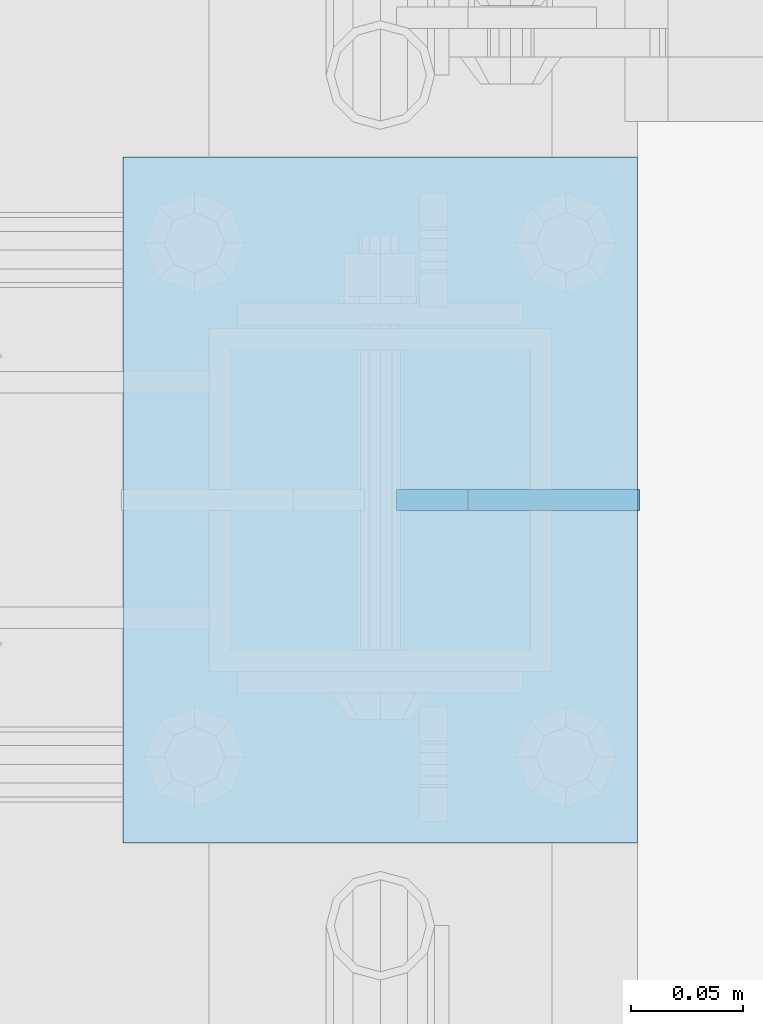
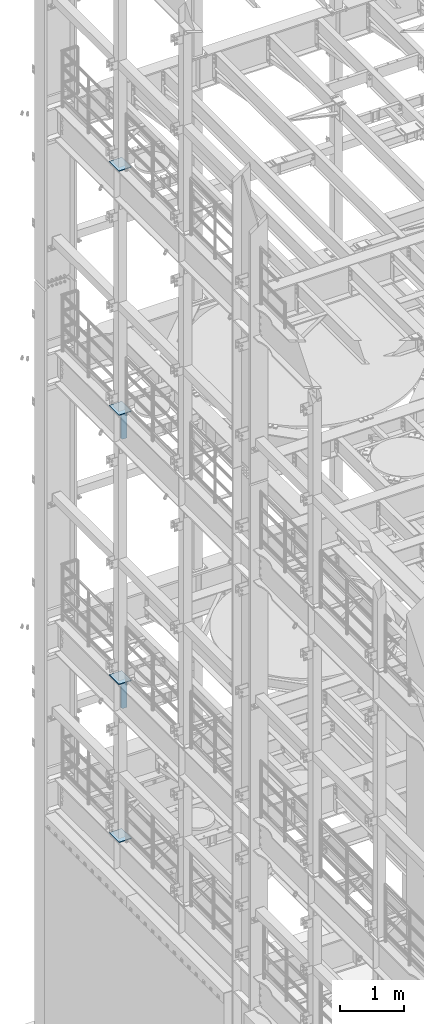
# One storey, part 1752 of 1876: 6 plates, 6 elements without a shape of their own.
"""IFC2X3 building model written with IfcOpenShell, lengths in millimetres."""

from ifc_helpers import new_model, si_unit, frame, origin_with_axes, place, context, subcontext, project, spatial, faceted_brep, material, type_object, element, aggregate, save


model = new_model("IFC2X3")

# Units and contexts
model_context = context("Model", 3, precision=1e-05, world=origin_with_axes())
body_context = subcontext(model_context, "Body", "Model", "MODEL_VIEW")
ifc_project = project(units=[si_unit("LENGTHUNIT", "METRE", prefix="MILLI"), si_unit("AREAUNIT", "SQUARE_METRE"), si_unit("VOLUMEUNIT", "CUBIC_METRE"), si_unit("MASSUNIT", "GRAM", prefix="KILO"), si_unit("TIMEUNIT", "SECOND"), si_unit("PLANEANGLEUNIT", "RADIAN"), si_unit("SOLIDANGLEUNIT", "STERADIAN"), si_unit("THERMODYNAMICTEMPERATUREUNIT", "DEGREE_CELSIUS"), si_unit("LUMINOUSINTENSITYUNIT", "LUMEN")], contexts=[model_context])

# Site, building, storey
site_placement = place(None, origin_with_axes())
site = spatial("IfcSite", under=ifc_project, at=site_placement, CompositionType="ELEMENT")
building_placement = place(site_placement, origin_with_axes())
building = spatial("IfcBuilding", under=site, at=building_placement, Name="Undefined", CompositionType="ELEMENT")
storey_placement = place(building_placement, origin_with_axes())
storey = spatial("IfcBuildingStorey", under=building, at=storey_placement, Name="Undefined", CompositionType="ELEMENT", Elevation=0.0)

# Assembly, plate
assembly_1_placement = place(storey_placement, origin_with_axes())
assembly_1 = element("IfcElementAssembly", 1, at=assembly_1_placement, inside=storey, Name="BEAM", AssemblyPlace="NOTDEFINED", PredefinedType="RIGID_FRAME")
ifc_material = material(Name="STEEL/A36")
plate_type_1 = type_object("IfcPlateType", PredefinedType="NOTDEFINED")
plate_1_placement = place(assembly_1_placement, frame((115.093723257727, 11684.0000002562, 12712.7), z_axis=(0.0, 0.0, 1.0), x_axis=(-1.0, 0.0, 0.0)))
plate_1 = element("IfcPlate", 2, at=plate_1_placement, type_object=plate_type_1, material=ifc_material, Name="PLATE", context=body_context, shape_type="Brep", body=[
    faceted_brep([(0.0, -4.76249999999982, 0.0), (0.0, -4.76249999999982, 571.5), (0.0, 4.76249999999982, 571.5), (0.0, 4.76249999999982, 0.0), (76.1999969482422, -4.76249999999982, 571.5), (76.1999969482422, 4.76249999999982, 571.5), (107.949996948242, -4.76249999999982, 539.75), (107.949996948242, 4.76249999999982, 539.75), (107.949996948242, -4.76249999999982, 31.75), (107.949996948242, 4.76249999999982, 31.75), (76.1999969482422, -4.76250000000073, 0.0), (76.1999969482422, 4.76250000000073, 0.0)], [[[0, 1, 2, 3]], [[1, 4, 5, 2]], [[4, 6, 7, 5]], [[6, 8, 9, 7]], [[8, 10, 11, 9]], [[10, 0, 3, 11]], [[5, 7, 9, 11, 3, 2]], [[10, 8, 6, 4, 1, 0]]]),
])
aggregate(assembly_1, [plate_1])

assembly_2_placement = place(storey_placement, origin_with_axes())
assembly_2 = element("IfcElementAssembly", 3, at=assembly_2_placement, inside=storey, Name="BEAM", AssemblyPlace="NOTDEFINED", PredefinedType="RIGID_FRAME")
plate_2_placement = place(assembly_2_placement, frame((115.09375, 11684.0, 7556.5), z_axis=(0.0, 0.0, 1.0), x_axis=(-1.0, 0.0, 0.0)))
plate_2 = element("IfcPlate", 4, at=plate_2_placement, type_object=plate_type_1, material=ifc_material, Name="PLATE", context=body_context, shape_type="Brep", body=[
    faceted_brep([(0.0, -4.76249999999982, 0.0), (0.0, -4.76249999999982, 571.5), (0.0, 4.76249999999982, 571.5), (0.0, 4.76249999999982, 0.0), (76.1999969482422, -4.76249999999982, 571.5), (76.1999969482422, 4.76249999999982, 571.5), (107.949996948242, -4.76249999999982, 539.75), (107.949996948242, 4.76249999999982, 539.75), (107.949996948242, -4.76249999999982, 31.75), (107.949996948242, 4.76249999999982, 31.75), (76.1999969482422, -4.76250000000073, 0.0), (76.1999969482422, 4.76250000000073, 0.0)], [[[0, 1, 2, 3]], [[1, 4, 5, 2]], [[4, 6, 7, 5]], [[6, 8, 9, 7]], [[8, 10, 11, 9]], [[10, 0, 3, 11]], [[5, 7, 9, 11, 3, 2]], [[10, 8, 6, 4, 1, 0]]]),
])
aggregate(assembly_2, [plate_2])

assembly_3_placement = place(storey_placement, origin_with_axes())
assembly_3 = element("IfcElementAssembly", 5, at=assembly_3_placement, inside=storey, Name="BEAM", AssemblyPlace="NOTDEFINED", PredefinedType="RIGID_FRAME")
plate_type_2 = type_object("IfcPlateType", PredefinedType="NOTDEFINED")
plate_3_placement = place(assembly_3_placement, frame((-114.3, 11531.6, 17989.55), z_axis=(0.0, 1.0, 0.0), x_axis=(1.0, 0.0, 0.0)))
plate_3 = element("IfcPlate", 6, at=plate_3_placement, type_object=plate_type_2, material=ifc_material, Name="PLATE", context=body_context, shape_type="Brep", body=[
    faceted_brep([(0.0, -6.35000000000036, 0.0), (0.0, -6.35000000000036, 304.799987792969), (0.0, 6.35000000000036, 304.799987792969), (0.0, 6.35000000000036, 0.0), (228.600006103516, -6.34999999999854, 304.799987792969), (228.600006103516, 6.34999999999854, 304.799987792969), (228.600006103516, -6.34999999999854, 0.0), (228.600006103516, 6.34999999999854, 0.0)], [[[0, 1, 2, 3]], [[1, 4, 5, 2]], [[4, 6, 7, 5]], [[6, 0, 3, 7]], [[5, 7, 3, 2]], [[6, 4, 1, 0]]]),
])
aggregate(assembly_3, [plate_3])

assembly_4_placement = place(storey_placement, origin_with_axes())
assembly_4 = element("IfcElementAssembly", 7, at=assembly_4_placement, inside=storey, Name="BEAM", AssemblyPlace="NOTDEFINED", PredefinedType="RIGID_FRAME")
plate_4_placement = place(assembly_4_placement, frame((-114.3, 11531.6, 13315.95), z_axis=(0.0, 1.0, 0.0), x_axis=(1.0, 0.0, 0.0)))
plate_4 = element("IfcPlate", 8, at=plate_4_placement, type_object=plate_type_2, material=ifc_material, Name="PLATE", context=body_context, shape_type="Brep", body=[
    faceted_brep([(0.0, -6.35000000000036, 0.0), (0.0, -6.35000000000036, 304.799987792969), (0.0, 6.35000000000036, 304.799987792969), (0.0, 6.35000000000036, 0.0), (228.600006103516, -6.34999999999854, 304.799987792969), (228.600006103516, 6.34999999999854, 304.799987792969), (228.600006103516, -6.34999999999854, 0.0), (228.600006103516, 6.34999999999854, 0.0)], [[[0, 1, 2, 3]], [[1, 4, 5, 2]], [[4, 6, 7, 5]], [[6, 0, 3, 7]], [[5, 7, 3, 2]], [[6, 4, 1, 0]]]),
])
aggregate(assembly_4, [plate_4])

assembly_5_placement = place(storey_placement, origin_with_axes())
assembly_5 = element("IfcElementAssembly", 9, at=assembly_5_placement, inside=storey, Name="BEAM", AssemblyPlace="NOTDEFINED", PredefinedType="RIGID_FRAME")
plate_5_placement = place(assembly_5_placement, frame((-114.3, 11531.6, 8159.75), z_axis=(0.0, 1.0, 0.0), x_axis=(1.0, 0.0, 0.0)))
plate_5 = element("IfcPlate", 10, at=plate_5_placement, type_object=plate_type_2, material=ifc_material, Name="PLATE", context=body_context, shape_type="Brep", body=[
    faceted_brep([(0.0, -6.35000000000036, 0.0), (0.0, -6.35000000000036, 304.799987792969), (0.0, 6.35000000000036, 304.799987792969), (0.0, 6.35000000000036, 0.0), (228.600006103516, -6.34999999999854, 304.799987792969), (228.600006103516, 6.34999999999854, 304.799987792969), (228.600006103516, -6.34999999999854, 0.0), (228.600006103516, 6.34999999999854, 0.0)], [[[0, 1, 2, 3]], [[1, 4, 5, 2]], [[4, 6, 7, 5]], [[6, 0, 3, 7]], [[5, 7, 3, 2]], [[6, 4, 1, 0]]]),
])
aggregate(assembly_5, [plate_5])

assembly_6_placement = place(storey_placement, origin_with_axes())
assembly_6 = element("IfcElementAssembly", 11, at=assembly_6_placement, inside=storey, Name="BEAM", AssemblyPlace="NOTDEFINED", PredefinedType="RIGID_FRAME")
plate_6_placement = place(assembly_6_placement, frame((-114.3, 11531.6, 5137.15), z_axis=(0.0, 1.0, 0.0), x_axis=(1.0, 0.0, 0.0)))
plate_6 = element("IfcPlate", 12, at=plate_6_placement, type_object=plate_type_2, material=ifc_material, Name="PLATE", context=body_context, shape_type="Brep", body=[
    faceted_brep([(0.0, -6.35000000000036, 0.0), (0.0, -6.35000000000036, 304.799987792969), (0.0, 6.35000000000036, 304.799987792969), (0.0, 6.35000000000036, 0.0), (228.600006103516, -6.34999999999854, 304.799987792969), (228.600006103516, 6.34999999999854, 304.799987792969), (228.600006103516, -6.34999999999854, 0.0), (228.600006103516, 6.34999999999854, 0.0)], [[[0, 1, 2, 3]], [[1, 4, 5, 2]], [[4, 6, 7, 5]], [[6, 0, 3, 7]], [[5, 7, 3, 2]], [[6, 4, 1, 0]]]),
])
aggregate(assembly_6, [plate_6])

save(model, "model.ifc")
